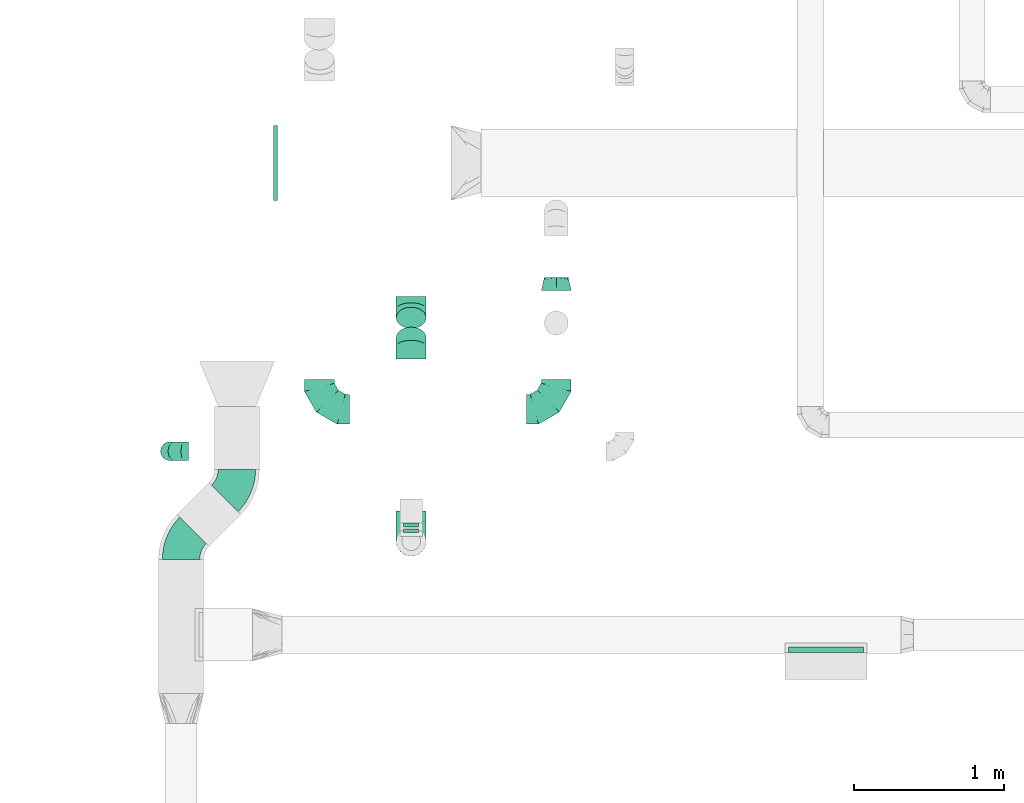
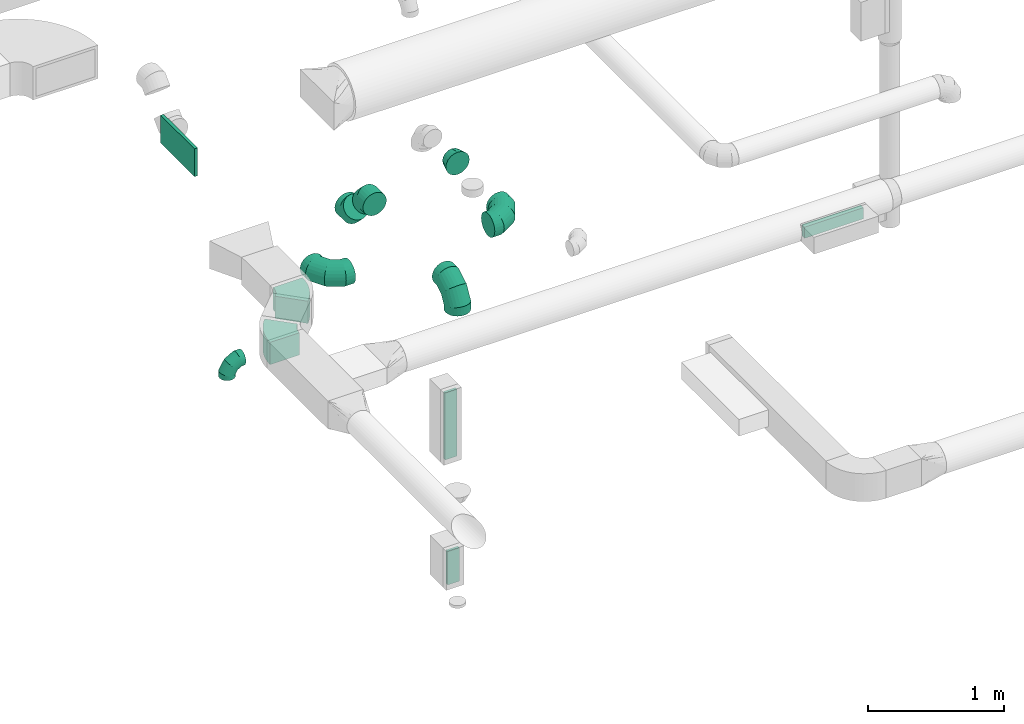
# One storey, part 50 of 97: 13 flow fittings.
"""IFC2X3 building model written with IfcOpenShell, lengths in millimetres."""

from ifc_helpers import new_model, entity, si_unit, converted_unit, derived_unit, direction, frame, frame_2d, origin, origin_2d_with_axis, place, context, subcontext, project, spatial, polyline, circle_curve, parameter, trimmed, segment, composite_curve, rectangle, outline, extrude, faceted_brep, source, transform, mapped, material, type_object, type_shapes, element, save


model = new_model("IFC2X3")

# Units and contexts
model_context = context("Model", 3, precision=0.01, world=origin(), true_north=direction((6.12303176911189e-17, 1.0)))
body_context = subcontext(model_context, "Body", "Model", "MODEL_VIEW")
ifc_project = project(units=[si_unit("LENGTHUNIT", "METRE", prefix="MILLI"), si_unit("AREAUNIT", "SQUARE_METRE"), si_unit("VOLUMEUNIT", "CUBIC_METRE"), converted_unit("PLANEANGLEUNIT", "DEGREE", entity("IfcRatioMeasure", 0.0174532925199433), si_unit("PLANEANGLEUNIT", "RADIAN"), dimensions=[0, 0, 0, 0, 0, 0, 0]), si_unit("MASSUNIT", "GRAM", prefix="KILO"), derived_unit("MASSDENSITYUNIT", [(si_unit("MASSUNIT", "GRAM", prefix="KILO"), 1), (si_unit("LENGTHUNIT", "METRE"), -3)]), derived_unit("MOMENTOFINERTIAUNIT", [(si_unit("LENGTHUNIT", "METRE"), 4)]), si_unit("TIMEUNIT", "SECOND"), si_unit("FREQUENCYUNIT", "HERTZ"), si_unit("THERMODYNAMICTEMPERATUREUNIT", "DEGREE_CELSIUS"), derived_unit("THERMALTRANSMITTANCEUNIT", [(si_unit("MASSUNIT", "GRAM", prefix="KILO"), 1), (si_unit("THERMODYNAMICTEMPERATUREUNIT", "KELVIN"), -1), (si_unit("TIMEUNIT", "SECOND"), -3)]), derived_unit("VOLUMETRICFLOWRATEUNIT", [(si_unit("LENGTHUNIT", "METRE"), 3), (si_unit("TIMEUNIT", "SECOND"), -1)]), derived_unit("MASSFLOWRATEUNIT", [(si_unit("MASSUNIT", "GRAM", prefix="KILO"), 1), (si_unit("TIMEUNIT", "SECOND"), -1)]), derived_unit("ROTATIONALFREQUENCYUNIT", [(si_unit("TIMEUNIT", "SECOND"), -1)]), si_unit("ELECTRICCURRENTUNIT", "AMPERE"), si_unit("ELECTRICVOLTAGEUNIT", "VOLT"), si_unit("POWERUNIT", "WATT"), si_unit("FORCEUNIT", "NEWTON", prefix="KILO"), si_unit("ILLUMINANCEUNIT", "LUX"), si_unit("LUMINOUSFLUXUNIT", "LUMEN"), si_unit("LUMINOUSINTENSITYUNIT", "CANDELA"), derived_unit("USERDEFINED", [(si_unit("MASSUNIT", "GRAM", prefix="KILO"), -1), (si_unit("LENGTHUNIT", "METRE"), -2), (si_unit("TIMEUNIT", "SECOND"), 3), (si_unit("LUMINOUSFLUXUNIT", "LUMEN"), 1)]), derived_unit("LINEARVELOCITYUNIT", [(si_unit("LENGTHUNIT", "METRE"), 1), (si_unit("TIMEUNIT", "SECOND"), -1)]), si_unit("PRESSUREUNIT", "PASCAL"), derived_unit("USERDEFINED", [(si_unit("LENGTHUNIT", "METRE"), -2), (si_unit("MASSUNIT", "GRAM", prefix="KILO"), 1), (si_unit("TIMEUNIT", "SECOND"), -2)]), derived_unit("LINEARFORCEUNIT", [(si_unit("MASSUNIT", "GRAM", prefix="KILO"), 1), (si_unit("LENGTHUNIT", "METRE"), 1), (si_unit("TIMEUNIT", "SECOND"), -2), (si_unit("LENGTHUNIT", "METRE"), -1)]), derived_unit("PLANARFORCEUNIT", [(si_unit("MASSUNIT", "GRAM", prefix="KILO"), 1), (si_unit("LENGTHUNIT", "METRE"), 1), (si_unit("TIMEUNIT", "SECOND"), -2), (si_unit("LENGTHUNIT", "METRE"), -2)])], contexts=[model_context])

# Site, building, storey
site_placement = place(None, origin())
site = spatial("IfcSite", under=ifc_project, at=site_placement, CompositionType="ELEMENT")
building_placement = place(site_placement, origin())
building = spatial("IfcBuilding", under=site, at=building_placement, CompositionType="ELEMENT")
storey_placement = place(building_placement, frame((0.0, 0.0, -4900.0)))
storey = spatial("IfcBuildingStorey", under=building, at=storey_placement, CompositionType="ELEMENT", Elevation=-4900.0)

# Flow fittings
ifc_material = material()
duct_fitting_type_1 = type_object("IfcDuctFittingType", PredefinedType="NOTDEFINED", material=ifc_material)
shared_shape_1 = source(origin(), body_context, "Body", "SweptSolid", [
    extrude(rectangle(XDim=26.0960000001476, YDim=300.0, at=origin_2d_with_axis()), frame((6.95, 0.0, -50.0)), (0.0, 0.0, 1.0), 100.0),
])
type_shapes(duct_fitting_type_1, [shared_shape_1])
flow_fitting_1_placement = place(storey_placement, frame((43625.66, 4260.82, 1450.0), z_axis=(1.0, 0.0, 0.0), x_axis=(0.0, 1.0, 0.0)))
element("IfcFlowFitting", 1, at=flow_fitting_1_placement, inside=storey, type_object=duct_fitting_type_1, material=ifc_material, context=body_context, shape_type="MappedRepresentation", body=[
    mapped(shared_shape_1, transform((0.0, 0.0, 0.0), scale=1.0)),
])
duct_fitting_type_2 = type_object("IfcDuctFittingType", PredefinedType="NOTDEFINED", material=ifc_material)
shared_shape_2 = source(origin(), body_context, "Body", "SweptSolid", [
    extrude(rectangle(XDim=39.4934596215632, YDim=500.0, at=origin_2d_with_axis()), frame((0.25, 0.0, -50.0)), (0.0, 0.0, 1.0), 100.0),
])
type_shapes(duct_fitting_type_2, [shared_shape_2])
flow_fitting_2_placement = place(storey_placement, frame((46394.41, 3473.53, 4050.0), z_axis=(0.0, 0.0, -1.0), x_axis=(0.0, -1.0, 0.0)))
element("IfcFlowFitting", 2, at=flow_fitting_2_placement, inside=storey, type_object=duct_fitting_type_2, material=ifc_material, context=body_context, shape_type="MappedRepresentation", body=[
    mapped(shared_shape_2, transform((0.0, 0.0, 0.0), scale=1.0)),
])
duct_fitting_type_3 = type_object("IfcDuctFittingType", PredefinedType="NOTDEFINED", material=ifc_material)
shared_shape_3 = source(origin(), body_context, "Body", "SweptSolid", [
    extrude(rectangle(XDim=26.0960000000009, YDim=600.0, at=origin_2d_with_axis()), frame((6.95, 0.0, -50.0)), (0.0, 0.0, 1.0), 100.0),
])
type_shapes(duct_fitting_type_3, [shared_shape_3])
flow_fitting_3_placement = place(storey_placement, frame((43625.66, 4298.32, 2700.0), z_axis=(1.0, 9.81578986608324e-06, 0.0), x_axis=(-9.81578986608324e-06, 1.0, 0.0)))
element("IfcFlowFitting", 3, at=flow_fitting_3_placement, inside=storey, type_object=duct_fitting_type_3, material=ifc_material, context=body_context, shape_type="MappedRepresentation", body=[
    mapped(shared_shape_3, transform((0.0, 0.0, 0.0), scale=1.0)),
])
duct_fitting_type_4 = type_object("IfcDuctFittingType", PredefinedType="NOTDEFINED", material=ifc_material)
shared_shape_4 = source(origin(), body_context, "Body", "SweptSolid", [
    extrude(rectangle(XDim=500.0, YDim=26.0960000001386, at=origin_2d_with_axis()), frame((6.95, 0.0, -125.0), z_axis=(0.0, 0.0, 1.0), x_axis=(0.0, -1.0, 0.0)), (0.0, 0.0, 1.0), 250.0),
])
type_shapes(duct_fitting_type_4, [shared_shape_4])
flow_fitting_4_placement = place(storey_placement, frame((42712.6, 6723.09, 4050.0), z_axis=(0.0, 0.0, -1.0), x_axis=(1.0, 0.0, 0.0)))
element("IfcFlowFitting", 4, at=flow_fitting_4_placement, inside=storey, type_object=duct_fitting_type_4, material=ifc_material, context=body_context, shape_type="MappedRepresentation", body=[
    mapped(shared_shape_4, transform((0.0, 0.0, 0.0), scale=1.0)),
])
duct_fitting_type_5 = type_object("IfcDuctFittingType", PredefinedType="NOTDEFINED", material=ifc_material)
shared_shape_5 = source(origin(), body_context, "Body", "Brep", [
    faceted_brep([(-200.0, 0.0, -100.0), (-200.0, -25.88, -96.59), (-200.0, -50.0, -86.6), (-200.0, -70.71, -70.71), (-200.0, -86.6, -50.0), (-200.0, -96.59, -25.88), (-200.0, -100.0, 0.0), (-200.0, -96.59, 25.88), (-200.0, -86.6, 50.0), (-200.0, -70.71, 70.71), (-200.0, -50.0, 86.6), (-200.0, -25.88, 96.59), (-200.0, 0.0, 100.0), (-200.0, 25.88, 96.59), (-200.0, 50.0, 86.6), (-200.0, 70.71, 70.71), (-200.0, 86.6, 50.0), (-200.0, 96.59, 25.88), (-200.0, 100.0, 0.0), (-200.0, 96.59, -25.88), (-200.0, 86.6, -50.0), (-200.0, 70.71, -70.71), (-200.0, 50.0, -86.6), (-200.0, 25.88, -96.59), (-153.35, 25.88, 96.59), (-159.81, 50.0, 86.6), (-146.41, 0.0, 100.0), (-165.36, 70.71, 70.71), (-172.29, 96.59, 25.88), (-173.21, 100.0, 0.0), (-169.62, 86.6, 50.0), (-169.62, 86.6, -50.0), (-165.36, 70.71, -70.71), (-172.29, 96.59, -25.88), (-153.35, 25.88, -96.59), (-146.41, 0.0, -100.0), (-159.81, 50.0, -86.6), (-139.48, -25.88, -96.59), (-133.01, -50.0, -86.6), (-127.46, -70.71, -70.71), (-123.21, -86.6, -50.0), (-120.53, -96.59, -25.88), (-119.62, -100.0, 0.0), (-120.53, -96.59, 25.88), (-123.21, -86.6, 50.0), (-127.46, -70.71, 70.71), (-133.01, -50.0, 86.6), (-139.48, -25.88, 96.59), (-72.54, 72.54, 96.59), (-90.19, 90.19, 86.6), (-53.59, 53.59, 100.0), (-105.35, 105.35, 70.71), (-116.99, 116.99, 50.0), (-124.3, 124.3, 25.88), (-126.79, 126.79, 0.0), (-124.3, 124.3, -25.88), (-116.99, 116.99, -50.0), (-105.35, 105.35, -70.71), (-72.54, 72.54, -96.59), (-53.59, 53.59, -100.0), (-90.19, 90.19, -86.6), (-34.64, 34.64, -96.59), (-16.99, 16.99, -86.6), (-1.83, 1.83, -70.71), (9.81, -9.81, -50.0), (17.12, -17.12, -25.88), (19.62, -19.62, 0.0), (17.12, -17.12, 25.88), (9.81, -9.81, 50.0), (-1.83, 1.83, 70.71), (-16.99, 16.99, 86.6), (-34.64, 34.64, 96.59), (-25.88, 153.35, 96.59), (-50.0, 159.81, 86.6), (0.0, 146.41, 100.0), (-70.71, 165.36, 70.71), (-86.6, 169.62, 50.0), (-96.59, 172.29, 25.88), (-100.0, 173.21, 0.0), (-96.59, 172.29, -25.88), (-86.6, 169.62, -50.0), (-70.71, 165.36, -70.71), (-25.88, 153.35, -96.59), (0.0, 146.41, -100.0), (-50.0, 159.81, -86.6), (25.88, 139.48, -96.59), (50.0, 133.01, -86.6), (70.71, 127.46, -70.71), (86.6, 123.21, -50.0), (96.59, 120.53, -25.88), (100.0, 119.62, 0.0), (96.59, 120.53, 25.88), (86.6, 123.21, 50.0), (70.71, 127.46, 70.71), (50.0, 133.01, 86.6), (25.88, 139.48, 96.59), (-25.88, 200.0, -96.59), (-50.0, 200.0, -86.6), (-70.71, 200.0, -70.71), (-86.6, 200.0, -50.0), (-96.59, 200.0, -25.88), (-100.0, 200.0, 0.0), (-96.59, 200.0, 25.88), (-86.6, 200.0, 50.0), (-70.71, 200.0, 70.71), (-50.0, 200.0, 86.6), (-25.88, 200.0, 96.59), (0.0, 200.0, 100.0), (25.88, 200.0, 96.59), (50.0, 200.0, 86.6), (70.71, 200.0, 70.71), (86.6, 200.0, 50.0), (96.59, 200.0, 25.88), (100.0, 200.0, 0.0), (96.59, 200.0, -25.88), (86.6, 200.0, -50.0), (70.71, 200.0, -70.71), (50.0, 200.0, -86.6), (25.88, 200.0, -96.59), (0.0, 200.0, -100.0)], [[[0, 1, 2, 3, 4, 5, 6, 7, 8, 9, 10, 11, 12, 13, 14, 15, 16, 17, 18, 19, 20, 21, 22, 23]], [[24, 25, 14, 13]], [[26, 24, 13, 12]], [[14, 25, 27, 15]], [[28, 29, 18, 17]], [[30, 28, 17, 16]], [[15, 27, 30, 16]], [[20, 31, 32, 21]], [[33, 31, 20, 19]], [[18, 29, 33, 19]], [[34, 35, 0, 23]], [[36, 34, 23, 22]], [[32, 36, 22, 21]], [[1, 0, 35, 37]], [[2, 1, 37, 38]], [[38, 39, 3, 2]], [[5, 4, 40, 41]], [[6, 5, 41, 42]], [[39, 40, 4, 3]], [[6, 42, 43, 7]], [[7, 43, 44, 8]], [[8, 44, 45, 9]], [[9, 45, 46, 10]], [[10, 46, 47, 11]], [[26, 12, 11, 47]], [[48, 49, 25, 24]], [[50, 48, 24, 26]], [[27, 25, 49, 51]], [[52, 53, 28, 30]], [[51, 52, 30, 27]], [[29, 28, 53, 54]], [[55, 56, 31, 33]], [[54, 55, 33, 29]], [[32, 31, 56, 57]], [[58, 59, 35, 34]], [[60, 58, 34, 36]], [[57, 60, 36, 32]], [[37, 35, 59, 61]], [[38, 37, 61, 62]], [[39, 38, 62, 63]], [[41, 40, 64, 65]], [[42, 41, 65, 66]], [[63, 64, 40, 39]], [[43, 42, 66, 67]], [[44, 43, 67, 68]], [[68, 69, 45, 44]], [[46, 45, 69, 70]], [[47, 46, 70, 71]], [[26, 47, 71, 50]], [[72, 73, 49, 48]], [[74, 72, 48, 50]], [[51, 49, 73, 75]], [[76, 77, 53, 52]], [[75, 76, 52, 51]], [[54, 53, 77, 78]], [[79, 80, 56, 55]], [[78, 79, 55, 54]], [[57, 56, 80, 81]], [[82, 83, 59, 58]], [[84, 82, 58, 60]], [[81, 84, 60, 57]], [[61, 59, 83, 85]], [[62, 61, 85, 86]], [[63, 62, 86, 87]], [[65, 64, 88, 89]], [[66, 65, 89, 90]], [[87, 88, 64, 63]], [[67, 66, 90, 91]], [[68, 67, 91, 92]], [[92, 93, 69, 68]], [[70, 69, 93, 94]], [[71, 70, 94, 95]], [[50, 71, 95, 74]], [[96, 97, 98, 99, 100, 101, 102, 103, 104, 105, 106, 107, 108, 109, 110, 111, 112, 113, 114, 115, 116, 117, 118, 119]], [[72, 74, 107, 106]], [[73, 72, 106, 105]], [[75, 73, 105, 104]], [[102, 101, 78, 77]], [[103, 102, 77, 76]], [[75, 104, 103, 76]], [[78, 101, 100, 79]], [[79, 100, 99, 80]], [[80, 99, 98, 81]], [[84, 97, 96, 82]], [[82, 96, 119, 83]], [[84, 81, 98, 97]], [[118, 117, 86, 85]], [[119, 118, 85, 83]], [[116, 87, 86, 117]], [[88, 115, 114, 89]], [[89, 114, 113, 90]], [[115, 88, 87, 116]], [[91, 90, 113, 112]], [[92, 91, 112, 111]], [[111, 110, 93, 92]], [[95, 94, 109, 108]], [[74, 95, 108, 107]], [[110, 109, 94, 93]]]),
])
type_shapes(duct_fitting_type_5, [shared_shape_5])
flow_fitting_5_placement = place(storey_placement, frame((43625.66, 4198.32, 4000.0), z_axis=(1.0, 0.0, 0.0), x_axis=(0.0, -1.0, 0.0)))
element("IfcFlowFitting", 5, at=flow_fitting_5_placement, inside=storey, type_object=duct_fitting_type_5, material=ifc_material, context=body_context, shape_type="MappedRepresentation", body=[
    mapped(shared_shape_5, transform((0.0, 0.0, 0.0), scale=1.0)),
])
flow_fitting_6_placement = place(storey_placement, frame((44594.05, 5078.77, 3750.0)))
element("IfcFlowFitting", 6, at=flow_fitting_6_placement, inside=storey, type_object=duct_fitting_type_5, material=ifc_material, context=body_context, shape_type="MappedRepresentation", body=[
    mapped(shared_shape_5, transform((0.0, 0.0, 0.0), scale=1.0)),
])
flow_fitting_7_placement = place(storey_placement, frame((43012.65, 5078.77, 3750.0), z_axis=(0.0, 0.0, 1.0), x_axis=(0.0, -1.0, 0.0)))
element("IfcFlowFitting", 7, at=flow_fitting_7_placement, inside=storey, type_object=duct_fitting_type_5, material=ifc_material, context=body_context, shape_type="MappedRepresentation", body=[
    mapped(shared_shape_5, transform((0.0, 0.0, 0.0), scale=1.0)),
])
duct_fitting_type_6 = type_object("IfcDuctFittingType", PredefinedType="NOTDEFINED", material=ifc_material)
shared_shape_6 = source(origin(), body_context, "Body", "Brep", [
    faceted_brep([(-125.0, 0.0, -62.5), (-125.0, -16.18, -60.37), (-125.0, -31.25, -54.13), (-125.0, -44.19, -44.19), (-125.0, -54.13, -31.25), (-125.0, -60.37, -16.18), (-125.0, -62.5, 0.0), (-125.0, -60.37, 16.18), (-125.0, -54.13, 31.25), (-125.0, -44.19, 44.19), (-125.0, -31.25, 54.13), (-125.0, -16.18, 60.37), (-125.0, 0.0, 62.5), (-125.0, 16.18, 60.37), (-125.0, 31.25, 54.13), (-125.0, 44.19, 44.19), (-125.0, 54.13, 31.25), (-125.0, 60.37, 16.18), (-125.0, 62.5, 0.0), (-125.0, 60.37, -16.18), (-125.0, 54.13, -31.25), (-125.0, 44.19, -44.19), (-125.0, 31.25, -54.13), (-125.0, 16.18, -60.37), (-95.84, 16.18, 60.37), (-99.88, 31.25, 54.13), (-91.51, 0.0, 62.5), (-103.35, 44.19, 44.19), (-107.68, 60.37, 16.18), (-108.25, 62.5, 0.0), (-106.01, 54.13, 31.25), (-106.01, 54.13, -31.25), (-103.35, 44.19, -44.19), (-107.68, 60.37, -16.18), (-95.84, 16.18, -60.37), (-91.51, 0.0, -62.5), (-99.88, 31.25, -54.13), (-87.17, -16.18, -60.37), (-83.13, -31.25, -54.13), (-79.66, -44.19, -44.19), (-77.0, -54.13, -31.25), (-75.33, -60.37, -16.18), (-74.76, -62.5, 0.0), (-75.33, -60.37, 16.18), (-77.0, -54.13, 31.25), (-79.66, -44.19, 44.19), (-83.13, -31.25, 54.13), (-87.17, -16.18, 60.37), (-45.34, 45.34, 60.37), (-56.37, 56.37, 54.13), (-33.49, 33.49, 62.5), (-65.85, 65.85, 44.19), (-73.12, 73.12, 31.25), (-77.69, 77.69, 16.18), (-79.25, 79.25, 0.0), (-77.69, 77.69, -16.18), (-73.12, 73.12, -31.25), (-65.85, 65.85, -44.19), (-45.34, 45.34, -60.37), (-33.49, 33.49, -62.5), (-56.37, 56.37, -54.13), (-21.65, 21.65, -60.37), (-10.62, 10.62, -54.13), (-1.14, 1.14, -44.19), (6.13, -6.13, -31.25), (10.7, -10.7, -16.18), (12.26, -12.26, 0.0), (10.7, -10.7, 16.18), (6.13, -6.13, 31.25), (-1.14, 1.14, 44.19), (-10.62, 10.62, 54.13), (-21.65, 21.65, 60.37), (-16.18, 95.84, 60.37), (-31.25, 99.88, 54.13), (0.0, 91.51, 62.5), (-44.19, 103.35, 44.19), (-54.13, 106.01, 31.25), (-60.37, 107.68, 16.18), (-62.5, 108.25, 0.0), (-60.37, 107.68, -16.18), (-54.13, 106.01, -31.25), (-44.19, 103.35, -44.19), (-16.18, 95.84, -60.37), (0.0, 91.51, -62.5), (-31.25, 99.88, -54.13), (16.18, 87.17, -60.37), (31.25, 83.13, -54.13), (44.19, 79.66, -44.19), (54.13, 77.0, -31.25), (60.37, 75.33, -16.18), (62.5, 74.76, 0.0), (60.37, 75.33, 16.18), (54.13, 77.0, 31.25), (44.19, 79.66, 44.19), (31.25, 83.13, 54.13), (16.18, 87.17, 60.37), (-16.18, 125.0, -60.37), (-31.25, 125.0, -54.13), (-44.19, 125.0, -44.19), (-54.13, 125.0, -31.25), (-60.37, 125.0, -16.18), (-62.5, 125.0, 0.0), (-60.37, 125.0, 16.18), (-54.13, 125.0, 31.25), (-44.19, 125.0, 44.19), (-31.25, 125.0, 54.13), (-16.18, 125.0, 60.37), (0.0, 125.0, 62.5), (16.18, 125.0, 60.37), (31.25, 125.0, 54.13), (44.19, 125.0, 44.19), (54.13, 125.0, 31.25), (60.37, 125.0, 16.18), (62.5, 125.0, 0.0), (60.37, 125.0, -16.18), (54.13, 125.0, -31.25), (44.19, 125.0, -44.19), (31.25, 125.0, -54.13), (16.18, 125.0, -60.37), (0.0, 125.0, -62.5)], [[[0, 1, 2, 3, 4, 5, 6, 7, 8, 9, 10, 11, 12, 13, 14, 15, 16, 17, 18, 19, 20, 21, 22, 23]], [[24, 25, 14, 13]], [[26, 24, 13, 12]], [[14, 25, 27, 15]], [[28, 29, 18, 17]], [[30, 28, 17, 16]], [[15, 27, 30, 16]], [[20, 31, 32, 21]], [[33, 31, 20, 19]], [[18, 29, 33, 19]], [[34, 35, 0, 23]], [[36, 34, 23, 22]], [[21, 32, 36, 22]], [[1, 0, 35, 37]], [[2, 1, 37, 38]], [[38, 39, 3, 2]], [[5, 4, 40, 41]], [[6, 5, 41, 42]], [[39, 40, 4, 3]], [[6, 42, 43, 7]], [[7, 43, 44, 8]], [[45, 9, 8, 44]], [[9, 45, 46, 10]], [[10, 46, 47, 11]], [[26, 12, 11, 47]], [[48, 49, 25, 24]], [[50, 48, 24, 26]], [[27, 25, 49, 51]], [[52, 53, 28, 30]], [[51, 52, 30, 27]], [[29, 28, 53, 54]], [[55, 56, 31, 33]], [[54, 55, 33, 29]], [[57, 32, 31, 56]], [[58, 59, 35, 34]], [[60, 58, 34, 36]], [[57, 60, 36, 32]], [[37, 35, 59, 61]], [[38, 37, 61, 62]], [[39, 38, 62, 63]], [[41, 40, 64, 65]], [[42, 41, 65, 66]], [[63, 64, 40, 39]], [[43, 42, 66, 67]], [[44, 43, 67, 68]], [[68, 69, 45, 44]], [[46, 45, 69, 70]], [[47, 46, 70, 71]], [[26, 47, 71, 50]], [[72, 73, 49, 48]], [[74, 72, 48, 50]], [[51, 49, 73, 75]], [[76, 77, 53, 52]], [[75, 76, 52, 51]], [[54, 53, 77, 78]], [[79, 80, 56, 55]], [[78, 79, 55, 54]], [[81, 57, 56, 80]], [[82, 83, 59, 58]], [[84, 82, 58, 60]], [[81, 84, 60, 57]], [[61, 59, 83, 85]], [[62, 61, 85, 86]], [[63, 62, 86, 87]], [[65, 64, 88, 89]], [[66, 65, 89, 90]], [[87, 88, 64, 63]], [[67, 66, 90, 91]], [[68, 67, 91, 92]], [[92, 93, 69, 68]], [[70, 69, 93, 94]], [[71, 70, 94, 95]], [[50, 71, 95, 74]], [[96, 97, 98, 99, 100, 101, 102, 103, 104, 105, 106, 107, 108, 109, 110, 111, 112, 113, 114, 115, 116, 117, 118, 119]], [[72, 74, 107, 106]], [[73, 72, 106, 105]], [[75, 73, 105, 104]], [[77, 76, 103, 102]], [[78, 77, 102, 101]], [[75, 104, 103, 76]], [[78, 101, 100, 79]], [[79, 100, 99, 80]], [[80, 99, 98, 81]], [[96, 119, 83, 82]], [[97, 96, 82, 84]], [[84, 81, 98, 97]], [[83, 119, 118, 85]], [[85, 118, 117, 86]], [[116, 87, 86, 117]], [[88, 115, 114, 89]], [[89, 114, 113, 90]], [[115, 88, 87, 116]], [[91, 90, 113, 112]], [[92, 91, 112, 111]], [[111, 110, 93, 92]], [[95, 94, 109, 108]], [[74, 95, 108, 107]], [[110, 109, 94, 93]]]),
])
type_shapes(duct_fitting_type_6, [shared_shape_6])
flow_fitting_8_placement = place(storey_placement, frame((42015.31, 4798.63, 3520.0), z_axis=(0.0, 1.0, 0.0), x_axis=(0.0, 0.0, 1.0)))
element("IfcFlowFitting", 8, at=flow_fitting_8_placement, inside=storey, type_object=duct_fitting_type_6, material=ifc_material, context=body_context, shape_type="MappedRepresentation", body=[
    mapped(shared_shape_6, transform((0.0, 0.0, 0.0), scale=1.0)),
])
duct_fitting_type_7 = type_object("IfcDuctFittingType", PredefinedType="NOTDEFINED", material=ifc_material)
shared_shape_7 = source(origin(), body_context, "Body", "Brep", [
    faceted_brep([(85.0, -30.61, -73.91), (85.0, -15.31, -76.96), (85.0, 0.0, -80.0), (85.0, 15.31, -76.96), (85.0, 30.61, -73.91), (85.0, 43.59, -65.24), (85.0, 56.57, -56.57), (85.0, 65.24, -43.59), (85.0, 73.91, -30.61), (85.0, 76.96, -15.31), (85.0, 80.0, 0.0), (85.0, 76.96, 15.31), (85.0, 73.91, 30.61), (85.0, 65.24, 43.59), (85.0, 56.57, 56.57), (85.0, 43.59, 65.24), (85.0, 30.61, 73.91), (85.0, 15.31, 76.96), (85.0, 0.0, 80.0), (85.0, -15.31, 76.96), (85.0, -30.61, 73.91), (85.0, -43.59, 65.24), (85.0, -56.57, 56.57), (85.0, -65.24, 43.59), (85.0, -73.91, 30.61), (85.0, -76.96, 15.31), (85.0, -80.0, 0.0), (85.0, -76.96, -15.31), (85.0, -73.91, -30.61), (85.0, -65.24, -43.59), (85.0, -56.57, -56.57), (85.0, -43.59, -65.24), (0.0, -100.0, 0.0), (0.0, -95.11, 30.9), (0.0, -80.9, 58.78), (0.0, -58.78, 80.9), (0.0, -30.9, 95.11), (0.0, 0.0, 100.0), (0.0, 30.9, 95.11), (0.0, 58.78, 80.9), (0.0, 80.9, 58.78), (0.0, 95.11, 30.9), (0.0, 100.0, 0.0), (0.0, 95.11, -30.9), (0.0, 80.9, -58.78), (0.0, 58.78, -80.9), (0.0, 30.9, -95.11), (0.0, 0.0, -100.0), (0.0, -30.9, -95.11), (0.0, -58.78, -80.9), (0.0, -80.9, -58.78), (0.0, -95.11, -30.9)], [[[0, 1, 2, 3, 4, 5, 6, 7, 8, 9, 10, 11, 12, 13, 14, 15, 16, 17, 18, 19, 20, 21, 22, 23, 24, 25, 26, 27, 28, 29, 30, 31]], [[32, 33, 34, 35, 36, 37, 38, 39, 40, 41, 42, 43, 44, 45, 46, 47, 48, 49, 50, 51]], [[37, 17, 38]], [[16, 39, 38]], [[40, 14, 13, 12]], [[15, 14, 39, 16]], [[41, 12, 11]], [[10, 42, 11]], [[17, 16, 38]], [[40, 12, 41]], [[11, 42, 41]], [[17, 37, 18]], [[14, 40, 39]], [[32, 25, 33]], [[24, 34, 33]], [[35, 22, 21, 20]], [[23, 22, 34, 24]], [[36, 20, 19]], [[18, 37, 19]], [[25, 24, 33]], [[35, 20, 36]], [[19, 37, 36]], [[25, 32, 26]], [[22, 35, 34]], [[47, 1, 48]], [[0, 49, 48]], [[50, 30, 29, 28]], [[31, 30, 49, 0]], [[51, 28, 27]], [[26, 32, 27]], [[1, 0, 48]], [[50, 28, 51]], [[27, 32, 51]], [[1, 47, 2]], [[30, 50, 49]], [[42, 9, 43]], [[8, 44, 43]], [[45, 6, 5, 4]], [[7, 6, 44, 8]], [[46, 4, 3]], [[2, 47, 3]], [[9, 8, 43]], [[45, 4, 46]], [[3, 47, 46]], [[9, 42, 10]], [[6, 45, 44]]]),
])
type_shapes(duct_fitting_type_7, [shared_shape_7])
flow_fitting_9_placement = place(storey_placement, frame((44594.05, 5872.09, 3750.0), z_axis=(0.0, 0.0, 1.0), x_axis=(0.0, 1.0, 0.0)))
element("IfcFlowFitting", 9, at=flow_fitting_9_placement, inside=storey, type_object=duct_fitting_type_7, material=ifc_material, context=body_context, shape_type="MappedRepresentation", body=[
    mapped(shared_shape_7, transform((0.0, 0.0, 0.0), scale=1.0)),
])
duct_fitting_type_8 = type_object("IfcDuctFittingType", PredefinedType="NOTDEFINED", material=ifc_material)
shared_shape_8 = source(origin(), body_context, "Body", "Brep", [
    faceted_brep([(-82.84, 0.0, -100.0), (-82.84, -25.88, -96.59), (-82.84, -50.0, -86.6), (-82.84, -70.71, -70.71), (-82.84, -86.6, -50.0), (-82.84, -96.59, -25.88), (-82.84, -100.0, 0.0), (-82.84, -96.59, 25.88), (-82.84, -86.6, 50.0), (-82.84, -70.71, 70.71), (-82.84, -50.0, 86.6), (-82.84, -25.88, 96.59), (-82.84, 0.0, 100.0), (-82.84, 25.88, 96.59), (-82.84, 50.0, 86.6), (-82.84, 70.71, 70.71), (-82.84, 86.6, 50.0), (-82.84, 96.59, 25.88), (-82.84, 100.0, 0.0), (-82.84, 96.59, -25.88), (-82.84, 86.6, -50.0), (-82.84, 70.71, -70.71), (-82.84, 50.0, -86.6), (-82.84, 25.88, -96.59), (-10.72, 25.88, 96.59), (-20.71, 50.0, 86.6), (0.0, 0.0, 100.0), (-29.29, 70.71, 70.71), (-35.87, 86.6, 50.0), (-40.01, 96.59, 25.88), (-41.42, 100.0, 0.0), (-40.01, 96.59, -25.88), (-35.87, 86.6, -50.0), (-29.29, 70.71, -70.71), (-10.72, 25.88, -96.59), (0.0, 0.0, -100.0), (-20.71, 50.0, -86.6), (10.72, -25.88, -96.59), (20.71, -50.0, -86.6), (29.29, -70.71, -70.71), (35.87, -86.6, -50.0), (40.01, -96.59, -25.88), (41.42, -100.0, 0.0), (40.01, -96.59, 25.88), (35.87, -86.6, 50.0), (29.29, -70.71, 70.71), (20.71, -50.0, 86.6), (10.72, -25.88, 96.59), (58.58, 58.58, 100.0), (40.28, 76.88, 96.59), (23.22, 93.93, 86.6), (8.58, 108.58, 70.71), (-2.66, 119.82, 50.0), (-9.72, 126.88, 25.88), (-12.13, 129.29, 0.0), (-9.72, 126.88, -25.88), (-2.66, 119.82, -50.0), (8.58, 108.58, -70.71), (23.22, 93.93, -86.6), (40.28, 76.88, -96.59), (58.58, 58.58, -100.0), (76.88, 40.28, -96.59), (93.93, 23.22, -86.6), (108.58, 8.58, -70.71), (119.82, -2.66, -50.0), (126.88, -9.72, -25.88), (129.29, -12.13, 0.0), (126.88, -9.72, 25.88), (119.82, -2.66, 50.0), (108.58, 8.58, 70.71), (93.93, 23.22, 86.6), (76.88, 40.28, 96.59)], [[[0, 1, 2, 3, 4, 5, 6, 7, 8, 9, 10, 11, 12, 13, 14, 15, 16, 17, 18, 19, 20, 21, 22, 23]], [[24, 25, 14, 13]], [[26, 24, 13, 12]], [[14, 25, 27, 15]], [[28, 29, 17, 16]], [[28, 16, 15, 27]], [[30, 18, 17, 29]], [[31, 32, 20, 19]], [[30, 31, 19, 18]], [[32, 33, 21, 20]], [[34, 35, 0, 23]], [[36, 34, 23, 22]], [[33, 36, 22, 21]], [[1, 0, 35, 37]], [[2, 1, 37, 38]], [[38, 39, 3, 2]], [[5, 4, 40, 41]], [[6, 5, 41, 42]], [[39, 40, 4, 3]], [[6, 42, 43, 7]], [[7, 43, 44, 8]], [[8, 44, 45, 9]], [[9, 45, 46, 10]], [[10, 46, 47, 11]], [[26, 12, 11, 47]], [[24, 26, 48, 49]], [[25, 24, 49, 50]], [[27, 25, 50, 51]], [[29, 28, 52, 53]], [[30, 29, 53, 54]], [[51, 52, 28, 27]], [[30, 54, 55, 31]], [[31, 55, 56, 32]], [[57, 33, 32, 56]], [[36, 58, 59, 34]], [[34, 59, 60, 35]], [[58, 36, 33, 57]], [[35, 60, 61, 37]], [[37, 61, 62, 38]], [[63, 39, 38, 62]], [[40, 64, 65, 41]], [[41, 65, 66, 42]], [[64, 40, 39, 63]], [[43, 42, 66, 67]], [[44, 43, 67, 68]], [[68, 69, 45, 44]], [[47, 46, 70, 71]], [[26, 47, 71, 48]], [[69, 70, 46, 45]], [[59, 58, 57, 56, 55, 54, 53, 52, 51, 50, 49, 48, 71, 70, 69, 68, 67, 66, 65, 64, 63, 62, 61, 60]]]),
])
type_shapes(duct_fitting_type_8, [shared_shape_8])
for number, where, z_axis, x_axis in (
    (10, (43625.66, 5497.71, 4000.0), (-1.0, 0.0, 0.0), (0.0, 1.0, 0.0)),
    (11, (43625.66, 5747.71, 3750.0), (1.0, 0.0, 0.0), (0.0, 0.707106781186518, -0.707106781186577)),
):
    element("IfcFlowFitting", number, at=place(storey_placement, frame(where, z_axis=z_axis, x_axis=x_axis)), inside=storey, type_object=duct_fitting_type_8, material=ifc_material, context=body_context, shape_type="MappedRepresentation", body=[
        mapped(shared_shape_8, transform((0.0, 0.0, 0.0), scale=1.0)),
    ])
duct_fitting_type_9 = type_object("IfcDuctFittingType", PredefinedType="NOTDEFINED", material=ifc_material)
shared_shape_9 = source(origin(), body_context, "Body", "SweptSolid", [
    extrude(outline(composite_curve([segment(polyline([(-165.27, -97.23), (84.73, -97.23)]), True, "CONTINUOUS"), segment(trimmed(circle_curve(frame_2d((234.73, -97.23), x_axis=(-0.707106781186546, 0.707106781186546)), 150.0), [parameter(0.0)], [parameter(45.0)], True, "PARAMETER"), False, "CONTINUOUS"), segment(polyline([(128.66, 8.84), (-48.12, 185.62)]), True, "CONTINUOUS"), segment(trimmed(circle_curve(frame_2d((234.73, -97.23), x_axis=(-0.707106781186546, 0.707106781186546)), 400.0), [parameter(0.0)], [parameter(45.0)], True, "PARAMETER"), True, "CONTINUOUS")], self_intersect=False)), frame((-16.68, 40.27, -100.0), z_axis=(0.0, 0.0, 1.0), x_axis=(-0.707106781186547, 0.707106781186548, 0.0)), (0.0, 0.0, 1.0), 200.0),
])
type_shapes(duct_fitting_type_9, [shared_shape_9])
for number, where, z_axis, x_axis in (
    (12, (42089.6, 4191.09, 4050.0), (0.0, 0.0, 1.0), (-0.707106781186559, -0.707106781186536, 0.0)),
    (13, (42462.6, 4564.09, 4050.0), (4.68856647490176e-08, -4.68856647490181e-08, 1.0), (0.707106781186551, 0.707106781186544, 0.0)),
):
    element("IfcFlowFitting", number, at=place(storey_placement, frame(where, z_axis=z_axis, x_axis=x_axis)), inside=storey, type_object=duct_fitting_type_9, material=ifc_material, context=body_context, shape_type="MappedRepresentation", body=[
        mapped(shared_shape_9, transform((0.0, 0.0, 0.0), scale=1.0)),
    ])

save(model, "model.ifc")
